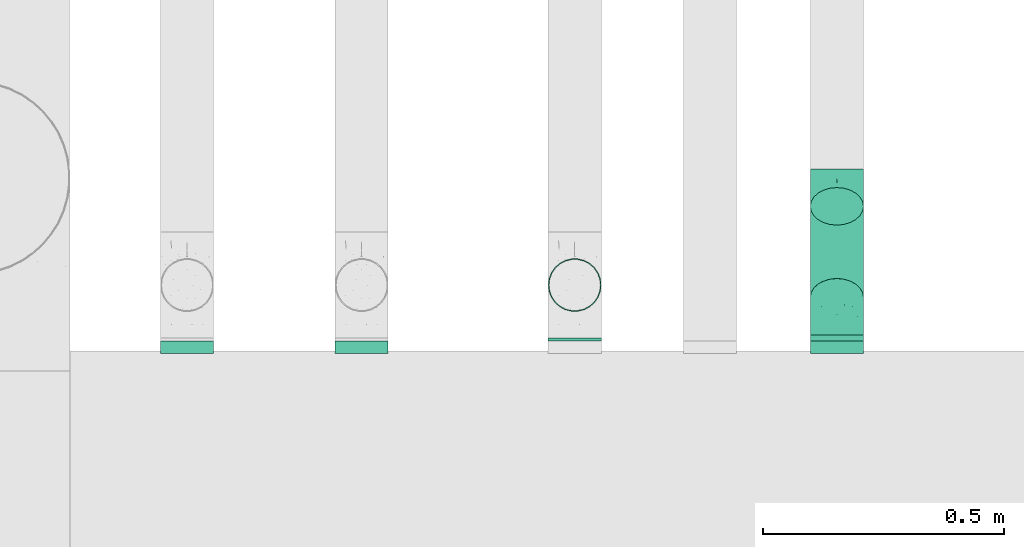
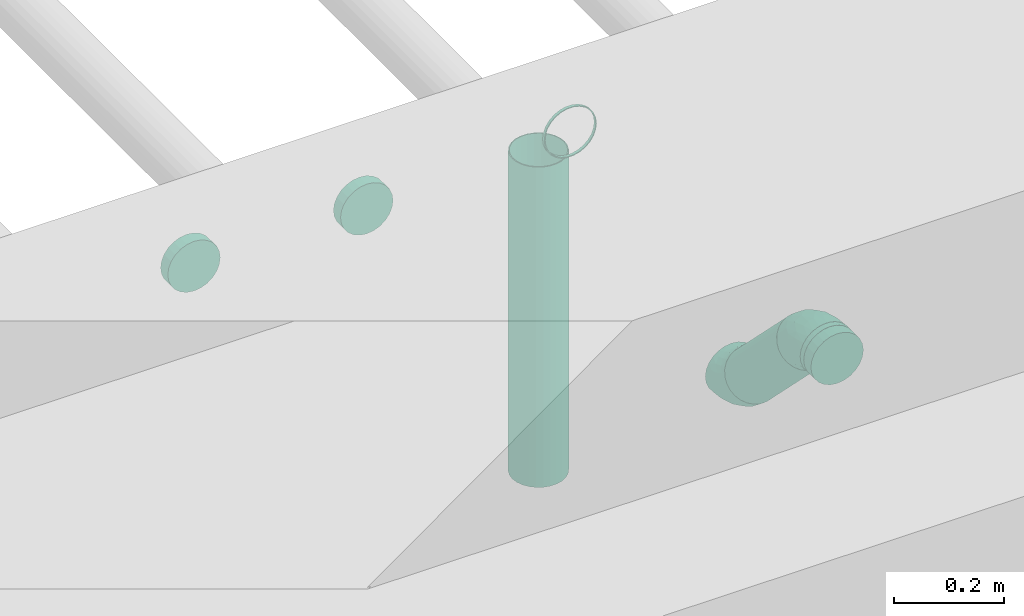
# One storey, part 51 of 91: 5 flow fittings, 4 flow segments.
"""IFC2X3 building model written with IfcOpenShell, lengths in millimetres."""

from ifc_helpers import new_model, entity, si_unit, converted_unit, derived_unit, direction, frame, origin_with_axes, origin_2d_with_axis, place, context, subcontext, project, spatial, hollow_circle, extrude, open_shell, surface_model, source, transform, mapped, material, layer, layer_set, layer_usage, type_object, element, save


model = new_model("IFC2X3")

# Units and contexts
model_context = context("Model", 3, precision=1e-05, world=origin_with_axes(), true_north=direction((0.0, 1.0)))
body_context = subcontext(model_context, "Body", "Model", "MODEL_VIEW")
ifc_project = project(units=[si_unit("AREAUNIT", "SQUARE_METRE"), si_unit("VOLUMEUNIT", "CUBIC_METRE", prefix="DECI"), si_unit("TIMEUNIT", "SECOND"), si_unit("THERMODYNAMICTEMPERATUREUNIT", "DEGREE_CELSIUS"), si_unit("PRESSUREUNIT", "PASCAL"), si_unit("MASSUNIT", "GRAM", prefix="KILO"), si_unit("LENGTHUNIT", "METRE", prefix="MILLI"), si_unit("POWERUNIT", "WATT"), si_unit("ELECTRICCURRENTUNIT", "AMPERE"), si_unit("ELECTRICVOLTAGEUNIT", "VOLT"), derived_unit("VOLUMETRICFLOWRATEUNIT", [(si_unit("VOLUMEUNIT", "CUBIC_METRE", prefix="DECI"), 1), (si_unit("TIMEUNIT", "SECOND"), -1)]), derived_unit("LINEARVELOCITYUNIT", [(si_unit("LENGTHUNIT", "METRE"), 1), (si_unit("TIMEUNIT", "SECOND"), -1)]), derived_unit("MASSDENSITYUNIT", [(si_unit("MASSUNIT", "GRAM", prefix="KILO"), 1), (si_unit("VOLUMEUNIT", "CUBIC_METRE"), -1)]), converted_unit("PLANEANGLEUNIT", "DEGREE", entity("IfcRatioMeasure", 0.01745), si_unit("PLANEANGLEUNIT", "RADIAN"), dimensions=[0, 0, 0, 0, 0, 0, 0])], contexts=[model_context])

# Site, building, storey
site_placement = place(None, origin_with_axes())
site = spatial("IfcSite", under=ifc_project, at=site_placement, CompositionType="ELEMENT")
building_placement = place(site_placement, origin_with_axes())
building = spatial("IfcBuilding", under=site, at=building_placement, Name="mc-building", CompositionType="ELEMENT")
storey_placement = place(building_placement, frame((0.0, 0.0, 8700.0), z_axis=(0.0, 0.0, 1.0), x_axis=(1.0, 0.0, 0.0)))
storey = spatial("IfcBuildingStorey", under=building, at=storey_placement, CompositionType="ELEMENT", Elevation=8700.0)

# Flow segments
ifc_material = material(Name="FZ1")
ifc_layer = layer(ifc_material, 0.0)
ifc_layer_set = layer_set([ifc_layer], Name="FZ1")
ifc_layer_usage = layer_usage(ifc_layer_set, "AXIS1", "POSITIVE", 0.0)
duct_segment_type = type_object("IfcDuctSegmentType", PredefinedType="RIGIDSEGMENT")
shared_shape_1 = source(origin_with_axes(), body_context, "Body", "SweptSolid", [
    extrude(hollow_circle(Radius=55.0, WallThickness=2.0, at=origin_2d_with_axis()), frame((0.0, 0.0, 0.0), z_axis=(1.0, 0.0, 0.0), x_axis=(0.0, 1.0, 0.0)), (0.0, 0.0, 1.0), 709.0),
])
flow_segment_1_placement = place(storey_placement, frame((19046.0369, 8426.54565, 1234.0), z_axis=(0.0, 1.0, 0.0), x_axis=(0.0, 0.0, -1.0)))
element("IfcFlowSegment", 1, at=flow_segment_1_placement, inside=storey, type_object=duct_segment_type, material=ifc_layer_usage, context=body_context, shape_type="MappedRepresentation", body=[
    mapped(shared_shape_1, transform((0.0, 0.0, 0.0), scale=1.0)),
])
shared_shape_2 = source(origin_with_axes(), body_context, "Body", "SweptSolid", [
    extrude(hollow_circle(Radius=55.0, WallThickness=2.0, at=origin_2d_with_axis()), frame((0.0, 0.0, 0.0), z_axis=(1.0, 0.0, 0.0), x_axis=(0.0, 1.0, 0.0)), (0.0, 0.0, 1.0), 266.7),
])
flow_segment_2_placement = place(storey_placement, frame((19589.29598, 8401.1274, 635.78175), z_axis=(0.0, 0.707107, 0.707107), x_axis=(0.0, 0.707107, -0.707107)))
element("IfcFlowSegment", 2, at=flow_segment_2_placement, inside=storey, type_object=duct_segment_type, material=ifc_layer_usage, context=body_context, shape_type="MappedRepresentation", body=[
    mapped(shared_shape_2, transform((0.0, 0.0, 0.0), scale=1.0)),
])

# Flow fittings
duct_fitting_type_1 = type_object("IfcDuctFittingType", Name="BU", PredefinedType="BEND")
shared_shape_3 = source(origin_with_axes(), body_context, "Body", "SurfaceModel", [
    surface_model("IfcShellBasedSurfaceModel", [(-45.56349, 0.0, -55.0), (-45.56349, -14.23505, -53.12592), (-45.56349, 14.23505, -53.12592), (-45.56349, 53.12592, 14.23505), (-45.56349, 27.5, -47.63139), (-45.56349, 38.89087, -38.89087), (-45.56349, 47.63139, -27.5), (-45.56349, -55.0, 0.0), (-45.56349, -53.12592, 14.23505), (-45.56349, -38.89087, -38.89087), (-45.56349, -27.5, -47.63139), (-45.56349, -53.12592, -14.23505), (-45.56349, -47.63139, -27.5), (-45.56349, 53.12592, -14.23505), (-45.56349, 47.63139, 27.5), (-45.56349, 38.89087, 38.89087), (-45.56349, -14.23505, 53.12592), (-45.56349, 27.5, 47.63139), (-45.56349, 14.23505, 53.12592), (-45.56349, -47.63139, 27.5), (-45.56349, -38.89087, 38.89087), (-45.56349, -27.5, 47.63139), (-45.56349, 0.0, 55.0), (-45.56349, 55.0, 0.0), (22.15256, 42.28395, -53.12592), (-6.67262, 71.10913, 0.0), (32.21826, 32.21826, -55.0), (12.77282, 51.66369, -47.63139), (-1.46223, 65.89874, -27.5), (4.71825, 59.71825, -38.89087), (59.71825, 4.71825, -38.89087), (69.78395, -5.34744, 14.23505), (51.66369, 12.77282, -47.63139), (42.28395, 22.15256, -53.12592), (65.89874, -1.46223, -27.5), (69.78395, -5.34744, -14.23505), (71.10913, -6.67262, 0.0), (-5.34744, 69.78395, -14.23505), (-5.34744, 69.78395, 14.23505), (-1.46223, 65.89874, 27.5), (4.71825, 59.71825, 38.89087), (32.21826, 32.21826, 55.0), (12.77282, 51.66369, 47.63139), (22.15256, 42.28395, 53.12592), (59.71825, 4.71825, 38.89087), (65.89874, -1.46223, 27.5), (42.28395, 22.15256, 53.12592), (51.66369, 12.77282, 47.63139), (-20.16649, 48.68621, 33.48188), (-26.97111, 35.77503, 43.63444), (-7.30443, 43.73336, 43.63444), (-17.0934, 3.74816, 55.0), (-18.00408, 15.44793, 53.78143), (-30.11707, 22.39897, 50.81337), (-7.49776, 55.63651, 33.48188), (-15.97018, 58.74288, 21.04759), (-31.18231, 52.58712, 21.04759), (-18.35174, 61.03934, 10.51509), (-28.67677, 56.60048, 10.47121), (-34.03924, 44.64267, 33.48188), (-11.52288, 27.81868, 50.81338), (1.19951, 23.16465, 53.81115), (-33.77926, 57.34403, 0.0), (5.4586, 37.12132, 50.81809), (-24.5159, 59.18663, 0.0), (-16.66281, 64.4339, 0.0), (9.43651, 14.73721, 55.0), (-6.22531, 44.36822, -43.63444), (5.4586, 37.12132, -50.81809), (-34.03924, 44.64267, -33.48188), (9.43651, 14.73721, -55.0), (-17.0934, 3.74816, -55.0), (1.19951, 23.16465, -53.81115), (-11.52288, 27.81868, -50.81338), (-30.11707, 22.39897, -50.81337), (-25.75914, 36.08917, -43.63444), (-30.24487, 52.83011, -21.04759), (-20.16649, 48.68621, -33.48188), (-7.49776, 55.63651, -33.48188), (-18.00408, 15.44793, -53.78143), (-28.68366, 56.62226, -10.35271), (-14.15883, 63.53074, -10.87592), (-15.13548, 59.23394, -21.04759), (3.19797, -7.72059, -52.16847), (3.1272, -18.04126, -47.9241), (13.63233, -32.91136, -32.06475), (45.23618, -22.99734, -20.4997), (16.67434, -40.25541, -15.9539), (-17.3935, -51.68264, -9.80849), (-2.85835, -49.37776, 0.0), (48.84421, -24.24609, -9.80849), (-16.38424, -42.76862, -30.85433), (-6.97383, -29.41689, -42.70541), (41.82739, -18.65658, -30.85433), (-15.72523, -48.24839, -20.4997), (29.28945, -13.63928, -42.80781), (26.81493, -3.56603, -49.15704), (36.93651, -32.89419, 0.0), (-15.72523, -48.24839, 20.4997), (-17.3935, -51.68264, 9.80849), (-16.38424, -42.76862, 30.85433), (16.67434, -40.25541, 15.9539), (3.19797, -7.72059, 52.16847), (10.54583, -14.96836, 47.9241), (13.63233, -32.91136, 32.06475), (45.23618, -22.99734, 20.4997), (41.82739, -18.65658, 30.85433), (-11.06635, -30.3552, 42.80781), (25.73213, -15.86964, 42.70541), (-16.43945, -21.48258, 49.15704), (48.84421, -24.24609, 9.80849)], [open_shell([[[0, 1, 2]], [[2, 3, 4]], [[5, 3, 6]], [[4, 3, 5]], [[2, 7, 8]], [[9, 7, 10]], [[1, 10, 7]], [[11, 7, 12]], [[9, 12, 7]], [[7, 2, 1]], [[13, 6, 3]], [[14, 3, 2]], [[15, 14, 2]], [[16, 17, 2]], [[2, 17, 15]], [[16, 18, 17]], [[19, 20, 2]], [[19, 2, 8]], [[20, 21, 2]], [[2, 21, 16]], [[16, 22, 18]], [[23, 13, 3]], [[24, 25, 26]], [[27, 25, 24]], [[28, 25, 29]], [[29, 25, 27]], [[30, 26, 31]], [[26, 30, 32]], [[32, 33, 26]], [[34, 31, 35]], [[31, 34, 30]], [[35, 31, 36]], [[37, 25, 28]], [[26, 38, 39]], [[26, 39, 40]], [[41, 40, 42]], [[26, 40, 41]], [[42, 43, 41]], [[26, 44, 45]], [[31, 26, 45]], [[46, 47, 26]], [[47, 44, 26]], [[46, 26, 41]], [[26, 25, 38]], [[48, 49, 50]], [[22, 51, 52]], [[17, 49, 15]], [[53, 17, 18]], [[49, 17, 53]], [[54, 50, 40]], [[48, 55, 56]], [[55, 57, 58]], [[59, 14, 15]], [[60, 53, 52]], [[50, 49, 60]], [[58, 3, 56]], [[52, 51, 61]], [[62, 23, 3]], [[63, 50, 60]], [[50, 42, 40]], [[3, 58, 62]], [[43, 61, 41]], [[62, 58, 64]], [[48, 59, 49]], [[14, 56, 3]], [[40, 39, 54]], [[57, 64, 58]], [[39, 38, 55]], [[63, 60, 61]], [[54, 55, 48]], [[65, 57, 38]], [[56, 14, 59]], [[38, 25, 65]], [[60, 52, 61]], [[49, 59, 15]], [[55, 58, 56]], [[56, 59, 48]], [[55, 54, 39]], [[50, 54, 48]], [[18, 22, 52]], [[49, 53, 60]], [[18, 52, 53]], [[61, 51, 66]], [[41, 61, 66]], [[63, 61, 43]], [[43, 42, 63]], [[50, 63, 42]], [[38, 57, 55]], [[64, 57, 65]], [[67, 27, 68]], [[69, 5, 6]], [[70, 71, 72]], [[73, 74, 75]], [[76, 77, 69]], [[29, 78, 28]], [[2, 79, 0]], [[13, 23, 62]], [[2, 74, 79]], [[5, 75, 4]], [[77, 78, 67]], [[13, 62, 80]], [[64, 80, 62]], [[81, 80, 64]], [[67, 73, 75]], [[82, 77, 76]], [[81, 64, 65]], [[76, 69, 6]], [[82, 76, 80]], [[24, 72, 68]], [[74, 2, 4]], [[27, 67, 29]], [[26, 70, 72]], [[69, 75, 5]], [[82, 28, 78]], [[72, 71, 79]], [[6, 13, 76]], [[77, 67, 75]], [[13, 80, 76]], [[82, 37, 28]], [[81, 25, 37]], [[82, 81, 37]], [[75, 69, 77]], [[67, 78, 29]], [[82, 78, 77]], [[75, 74, 4]], [[79, 74, 73]], [[79, 73, 72]], [[79, 71, 0]], [[68, 72, 73]], [[26, 72, 24]], [[67, 68, 73]], [[27, 24, 68]], [[80, 81, 82]], [[25, 81, 65]], [[1, 83, 84]], [[85, 86, 87]], [[0, 71, 1]], [[88, 87, 89]], [[90, 86, 35]], [[91, 92, 85]], [[11, 88, 7]], [[30, 34, 93]], [[11, 12, 94]], [[92, 91, 9]], [[85, 94, 91]], [[94, 85, 87]], [[95, 93, 85]], [[85, 92, 95]], [[83, 71, 70]], [[12, 9, 91]], [[70, 26, 33]], [[96, 84, 83]], [[1, 71, 83]], [[95, 96, 32]], [[95, 30, 93]], [[95, 32, 30]], [[97, 89, 87]], [[34, 86, 93]], [[36, 97, 90]], [[94, 88, 11]], [[34, 35, 86]], [[90, 87, 86]], [[93, 86, 85]], [[32, 96, 33]], [[84, 10, 1]], [[33, 83, 70]], [[94, 12, 91]], [[10, 92, 9]], [[87, 88, 94]], [[7, 88, 89]], [[36, 90, 35]], [[87, 90, 97]], [[84, 95, 92]], [[33, 96, 83]], [[95, 84, 96]], [[10, 84, 92]], [[8, 98, 19]], [[7, 89, 99]], [[19, 98, 100]], [[101, 98, 99]], [[46, 102, 103]], [[104, 105, 106]], [[100, 98, 104]], [[107, 104, 108]], [[16, 51, 22]], [[51, 16, 102]], [[107, 20, 100]], [[107, 109, 21]], [[21, 20, 107]], [[103, 47, 46]], [[101, 89, 97]], [[105, 110, 31]], [[44, 47, 108]], [[105, 104, 101]], [[107, 100, 104]], [[31, 110, 36]], [[109, 16, 21]], [[108, 106, 44]], [[105, 45, 106]], [[41, 66, 46]], [[102, 66, 51]], [[46, 66, 102]], [[104, 98, 101]], [[99, 98, 8]], [[106, 108, 104]], [[110, 101, 97]], [[45, 44, 106]], [[105, 31, 45]], [[20, 19, 100]], [[109, 103, 102]], [[101, 110, 105]], [[36, 110, 97]], [[7, 99, 8]], [[101, 99, 89]], [[103, 107, 108]], [[16, 109, 102]], [[107, 103, 109]], [[47, 103, 108]]])]),
])
for number, where, z_axis, x_axis, name in (
    (3, (19589.29598, 8368.90914, 668.0), (1.0, 0.0, 0.0), (0.0, -0.707107, 0.707107), "BU"),
    (4, (19589.29598, 8621.90914, 415.0), (-1.0, 0.0, 0.0), (0.0, -1.0, 0.0), "BU"),
):
    element("IfcFlowFitting", number, at=place(storey_placement, frame(where, z_axis=z_axis, x_axis=x_axis)), inside=storey, type_object=duct_fitting_type_1, Name=name, context=body_context, shape_type="MappedRepresentation", body=[
        mapped(shared_shape_3, transform((0.0, 0.0, 0.0), scale=1.0)),
    ])
duct_fitting_type_2 = type_object("IfcDuctFittingType", Name="CC", PredefinedType="CONNECTOR")
shared_shape_4 = source(origin_with_axes(), body_context, "Body", "SurfaceModel", [
    surface_model("IfcShellBasedSurfaceModel", [(-6.096, -55.0, 0.0), (-6.096, 0.0, -55.0), (-6.096, -14.23505, -53.12592), (-6.096, -27.5, -47.63139), (-6.096, -38.89087, -38.89087), (-6.096, -47.63139, -27.5), (-6.096, 38.89087, -38.89087), (-6.096, 53.12592, 14.23505), (-6.096, 27.5, -47.63139), (-6.096, 14.23505, -53.12592), (-6.096, 47.63139, -27.5), (-6.096, 53.12592, -14.23505), (-6.096, 55.0, 0.0), (-6.096, -53.12592, -14.23505), (-6.096, -53.12592, 14.23505), (-6.096, -47.63139, 27.5), (-6.096, -38.89087, 38.89087), (-6.096, 0.0, 55.0), (-6.096, -27.5, 47.63139), (-6.096, -14.23505, 53.12592), (-6.096, 38.89087, 38.89087), (-6.096, 47.63139, 27.5), (-6.096, 14.23505, 53.12592), (-6.096, 27.5, 47.63139), (0.0, -14.23505, 53.12592), (0.0, 0.0, 55.0), (0.0, -27.5, 47.63139), (0.0, -38.89087, 38.89087), (0.0, -53.12592, 14.23505), (0.0, -47.63139, 27.5), (0.0, -55.0, 0.0), (0.0, -53.12592, -14.23505), (0.0, -47.63139, -27.5), (0.0, -38.89087, -38.89087), (0.0, -14.23505, -53.12592), (0.0, -27.5, -47.63139), (0.0, 0.0, -55.0), (0.0, 14.23505, -53.12592), (0.0, 27.5, -47.63139), (0.0, 38.89087, -38.89087), (0.0, 53.12592, -14.23505), (0.0, 47.63139, -27.5), (0.0, 55.0, 0.0), (0.0, 53.12592, 14.23505), (0.0, 47.63139, 27.5), (0.0, 38.89087, 38.89087), (0.0, 14.23505, 53.12592), (0.0, 27.5, 47.63139), (20.0, 0.0, -55.0), (20.0, 14.23505, -53.12592), (20.0, -14.23505, -53.12592), (20.0, -53.12592, 14.23505), (20.0, -27.5, -47.63139), (20.0, -47.63139, -27.5), (20.0, -38.89087, -38.89087), (20.0, 55.0, 0.0), (20.0, 53.12592, 14.23505), (20.0, 38.89087, -38.89087), (20.0, 27.5, -47.63139), (20.0, 53.12592, -14.23505), (20.0, 47.63139, -27.5), (20.0, -53.12592, -14.23505), (20.0, -47.63139, 27.5), (20.0, -38.89087, 38.89087), (20.0, 14.23505, 53.12592), (20.0, -27.5, 47.63139), (20.0, -14.23505, 53.12592), (20.0, 47.63139, 27.5), (20.0, 38.89087, 38.89087), (20.0, 27.5, 47.63139), (20.0, 0.0, 55.0), (20.0, -55.0, 0.0)], [open_shell([[[0, 1, 2]], [[3, 0, 2]], [[0, 4, 5]], [[4, 0, 3]], [[6, 1, 7]], [[1, 6, 8]], [[8, 9, 1]], [[6, 7, 10]], [[10, 7, 11]], [[12, 11, 7]], [[13, 0, 5]], [[14, 15, 1]], [[1, 15, 16]], [[17, 16, 18]], [[17, 1, 16]], [[19, 17, 18]], [[20, 21, 1]], [[7, 1, 21]], [[22, 23, 1]], [[23, 20, 1]], [[22, 1, 17]], [[0, 14, 1]], [[24, 25, 17]], [[26, 24, 19]], [[19, 24, 17]], [[16, 27, 18]], [[26, 19, 18]], [[26, 18, 27]], [[28, 29, 15]], [[30, 28, 14]], [[15, 29, 16]], [[28, 15, 14]], [[30, 14, 0]], [[27, 16, 29]], [[31, 30, 0]], [[32, 31, 13]], [[13, 31, 0]], [[4, 33, 5]], [[32, 13, 5]], [[32, 5, 33]], [[34, 35, 3]], [[36, 34, 2]], [[3, 35, 4]], [[34, 3, 2]], [[36, 2, 1]], [[33, 4, 35]], [[37, 36, 1]], [[38, 37, 9]], [[9, 37, 1]], [[6, 39, 8]], [[38, 9, 8]], [[38, 8, 39]], [[40, 41, 10]], [[42, 40, 11]], [[10, 41, 6]], [[40, 10, 11]], [[42, 11, 12]], [[39, 6, 41]], [[43, 42, 12]], [[44, 43, 7]], [[7, 43, 12]], [[20, 45, 21]], [[44, 7, 21]], [[44, 21, 45]], [[46, 47, 23]], [[25, 46, 22]], [[23, 47, 20]], [[46, 23, 22]], [[25, 22, 17]], [[45, 20, 47]], [[48, 49, 50]], [[50, 51, 52]], [[53, 54, 51]], [[52, 51, 54]], [[50, 55, 56]], [[57, 55, 58]], [[49, 58, 55]], [[59, 55, 60]], [[57, 60, 55]], [[55, 50, 49]], [[53, 51, 61]], [[50, 62, 51]], [[63, 62, 50]], [[64, 65, 50]], [[65, 63, 50]], [[64, 66, 65]], [[50, 67, 68]], [[67, 50, 56]], [[68, 69, 50]], [[50, 69, 64]], [[64, 70, 66]], [[71, 61, 51]], [[66, 70, 25]], [[65, 66, 24]], [[24, 66, 25]], [[27, 63, 26]], [[65, 24, 26]], [[65, 26, 63]], [[51, 62, 29]], [[71, 51, 28]], [[29, 62, 27]], [[51, 29, 28]], [[71, 28, 30]], [[63, 27, 62]], [[61, 71, 30]], [[53, 61, 31]], [[31, 61, 30]], [[33, 54, 32]], [[53, 31, 32]], [[53, 32, 54]], [[50, 52, 35]], [[48, 50, 34]], [[35, 52, 33]], [[50, 35, 34]], [[48, 34, 36]], [[54, 33, 52]], [[49, 48, 36]], [[58, 49, 37]], [[37, 49, 36]], [[39, 57, 38]], [[58, 37, 38]], [[58, 38, 57]], [[59, 60, 41]], [[55, 59, 40]], [[41, 60, 39]], [[59, 41, 40]], [[55, 40, 42]], [[57, 39, 60]], [[56, 55, 42]], [[67, 56, 43]], [[43, 56, 42]], [[45, 68, 44]], [[67, 43, 44]], [[67, 44, 68]], [[64, 69, 47]], [[70, 64, 46]], [[47, 69, 45]], [[64, 47, 46]], [[70, 46, 25]], [[68, 45, 69]], [[50, 63, 62]], [[50, 64, 65]], [[50, 56, 67]], [[50, 68, 69]], [[64, 50, 69]]])]),
])
flow_fitting_placement = place(storey_placement, frame((19589.29598, 8290.34565, 668.0), z_axis=(0.0, 0.0, -1.0), x_axis=(0.0, 1.0, 0.0)))
element("IfcFlowFitting", 5, at=flow_fitting_placement, inside=storey, type_object=duct_fitting_type_2, Name="CC", context=body_context, shape_type="MappedRepresentation", body=[
    mapped(shared_shape_4, transform((0.0, 0.0, 0.0), scale=1.0)),
])

# Flow segments
shared_shape_5 = source(origin_with_axes(), body_context, "Body", "SweptSolid", [
    extrude(hollow_circle(Radius=55.0, WallThickness=2.0, at=origin_2d_with_axis()), frame((0.0, 0.0, 0.0), z_axis=(1.0, 0.0, 0.0), x_axis=(0.0, 1.0, 0.0)), (0.0, 0.0, 1.0), 13.0),
])
flow_segment_3_placement = place(storey_placement, frame((19589.29598, 8310.34565, 668.0), z_axis=(0.0, 0.0, 1.0), x_axis=(0.0, 1.0, 0.0)))
element("IfcFlowSegment", 6, at=flow_segment_3_placement, inside=storey, type_object=duct_segment_type, material=ifc_layer_usage, context=body_context, shape_type="MappedRepresentation", body=[
    mapped(shared_shape_5, transform((0.0, 0.0, 0.0), scale=1.0)),
])
shared_shape_6 = source(origin_with_axes(), body_context, "Body", "SweptSolid", [
    extrude(hollow_circle(Radius=55.0, WallThickness=2.0, at=origin_2d_with_axis()), frame((0.0, 0.0, 0.0), z_axis=(1.0, 0.0, 0.0), x_axis=(0.0, 1.0, 0.0)), (0.0, 0.0, 1.0), 6.2),
])
flow_segment_4_placement = place(storey_placement, frame((19046.0369, 8310.34565, 1344.0), z_axis=(0.0, 0.0, 1.0), x_axis=(0.0, 1.0, 0.0)))
element("IfcFlowSegment", 7, at=flow_segment_4_placement, inside=storey, type_object=duct_segment_type, material=ifc_layer_usage, context=body_context, shape_type="MappedRepresentation", body=[
    mapped(shared_shape_6, transform((0.0, 0.0, 0.0), scale=1.0, scale2=1.0, scale3=1.0, uniform=False)),
])

# Flow fittings
shared_shape_7 = source(origin_with_axes(), body_context, "Body", "SurfaceModel", [
    surface_model("IfcShellBasedSurfaceModel", [(-6.096, -55.0, 0.0), (-6.096, 0.0, -55.0), (-6.096, -14.23505, -53.12592), (-6.096, -27.5, -47.63139), (-6.096, -38.89087, -38.89087), (-6.096, -47.63139, -27.5), (-6.096, 38.89087, -38.89087), (-6.096, 53.12592, 14.23505), (-6.096, 27.5, -47.63139), (-6.096, 14.23505, -53.12592), (-6.096, 47.63139, -27.5), (-6.096, 53.12592, -14.23505), (-6.096, 55.0, 0.0), (-6.096, -53.12592, -14.23505), (-6.096, -53.12592, 14.23505), (-6.096, -47.63139, 27.5), (-6.096, -38.89087, 38.89087), (-6.096, 0.0, 55.0), (-6.096, -27.5, 47.63139), (-6.096, -14.23505, 53.12592), (-6.096, 38.89087, 38.89087), (-6.096, 47.63139, 27.5), (-6.096, 14.23505, 53.12592), (-6.096, 27.5, 47.63139), (0.0, -14.23505, 53.12592), (0.0, 0.0, 55.0), (0.0, -27.5, 47.63139), (0.0, -38.89087, 38.89087), (0.0, -53.12592, 14.23505), (0.0, -47.63139, 27.5), (0.0, -55.0, 0.0), (0.0, -53.12592, -14.23505), (0.0, -47.63139, -27.5), (0.0, -38.89087, -38.89087), (0.0, -14.23505, -53.12592), (0.0, -27.5, -47.63139), (0.0, 0.0, -55.0), (0.0, 14.23505, -53.12592), (0.0, 27.5, -47.63139), (0.0, 38.89087, -38.89087), (0.0, 53.12592, -14.23505), (0.0, 47.63139, -27.5), (0.0, 55.0, 0.0), (0.0, 53.12592, 14.23505), (0.0, 47.63139, 27.5), (0.0, 38.89087, 38.89087), (0.0, 14.23505, 53.12592), (0.0, 27.5, 47.63139), (20.0, 0.0, -55.0), (20.0, 14.23505, -53.12592), (20.0, -14.23505, -53.12592), (20.0, -53.12592, 14.23505), (20.0, -27.5, -47.63139), (20.0, -47.63139, -27.5), (20.0, -38.89087, -38.89087), (20.0, 55.0, 0.0), (20.0, 53.12592, 14.23505), (20.0, 38.89087, -38.89087), (20.0, 27.5, -47.63139), (20.0, 53.12592, -14.23505), (20.0, 47.63139, -27.5), (20.0, -53.12592, -14.23505), (20.0, -47.63139, 27.5), (20.0, -38.89087, 38.89087), (20.0, 14.23505, 53.12592), (20.0, -27.5, 47.63139), (20.0, -14.23505, 53.12592), (20.0, 47.63139, 27.5), (20.0, 38.89087, 38.89087), (20.0, 27.5, 47.63139), (20.0, 0.0, 55.0), (20.0, -55.0, 0.0)], [open_shell([[[0, 1, 2]], [[3, 0, 2]], [[0, 4, 5]], [[4, 0, 3]], [[6, 1, 7]], [[1, 6, 8]], [[8, 9, 1]], [[6, 7, 10]], [[10, 7, 11]], [[12, 11, 7]], [[13, 0, 5]], [[14, 15, 1]], [[1, 15, 16]], [[17, 16, 18]], [[17, 1, 16]], [[19, 17, 18]], [[20, 21, 1]], [[7, 1, 21]], [[22, 23, 1]], [[23, 20, 1]], [[22, 1, 17]], [[0, 14, 1]], [[24, 25, 17]], [[26, 24, 19]], [[19, 24, 17]], [[16, 27, 18]], [[26, 19, 18]], [[26, 18, 27]], [[28, 29, 15]], [[30, 28, 14]], [[15, 29, 16]], [[28, 15, 14]], [[30, 14, 0]], [[27, 16, 29]], [[31, 30, 0]], [[32, 31, 13]], [[13, 31, 0]], [[4, 33, 5]], [[32, 13, 5]], [[32, 5, 33]], [[34, 35, 3]], [[36, 34, 2]], [[3, 35, 4]], [[34, 3, 2]], [[36, 2, 1]], [[33, 4, 35]], [[37, 36, 1]], [[38, 37, 9]], [[9, 37, 1]], [[6, 39, 8]], [[38, 9, 8]], [[38, 8, 39]], [[40, 41, 10]], [[42, 40, 11]], [[10, 41, 6]], [[40, 10, 11]], [[42, 11, 12]], [[39, 6, 41]], [[43, 42, 12]], [[44, 43, 7]], [[7, 43, 12]], [[20, 45, 21]], [[44, 7, 21]], [[44, 21, 45]], [[46, 47, 23]], [[25, 46, 22]], [[23, 47, 20]], [[46, 23, 22]], [[25, 22, 17]], [[45, 20, 47]], [[48, 49, 50]], [[50, 51, 52]], [[53, 54, 51]], [[52, 51, 54]], [[50, 55, 56]], [[57, 55, 58]], [[49, 58, 55]], [[59, 55, 60]], [[57, 60, 55]], [[55, 50, 49]], [[53, 51, 61]], [[50, 62, 51]], [[63, 62, 50]], [[64, 65, 50]], [[65, 63, 50]], [[64, 66, 65]], [[50, 67, 68]], [[67, 50, 56]], [[68, 69, 50]], [[50, 69, 64]], [[64, 70, 66]], [[71, 61, 51]], [[66, 70, 25]], [[65, 66, 24]], [[24, 66, 25]], [[27, 63, 26]], [[65, 24, 26]], [[65, 26, 63]], [[51, 62, 29]], [[71, 51, 28]], [[29, 62, 27]], [[51, 29, 28]], [[71, 28, 30]], [[63, 27, 62]], [[61, 71, 30]], [[53, 61, 31]], [[31, 61, 30]], [[33, 54, 32]], [[53, 31, 32]], [[53, 32, 54]], [[50, 52, 35]], [[48, 50, 34]], [[35, 52, 33]], [[50, 35, 34]], [[48, 34, 36]], [[54, 33, 52]], [[49, 48, 36]], [[58, 49, 37]], [[37, 49, 36]], [[39, 57, 38]], [[58, 37, 38]], [[58, 38, 57]], [[59, 60, 41]], [[55, 59, 40]], [[41, 60, 39]], [[59, 41, 40]], [[55, 40, 42]], [[57, 39, 60]], [[56, 55, 42]], [[67, 56, 43]], [[43, 56, 42]], [[45, 68, 44]], [[67, 43, 44]], [[67, 44, 68]], [[64, 69, 47]], [[70, 64, 46]], [[47, 69, 45]], [[64, 47, 46]], [[70, 46, 25]], [[68, 45, 69]], [[50, 63, 62]], [[50, 64, 65]], [[50, 56, 67]], [[50, 68, 69]], [[64, 50, 69]]])]),
])
for number, where, z_axis, x_axis, name in (
    (8, (18242.77608, 8290.34565, 1344.0), (0.0, 0.0, -1.0), (0.0, 1.0, 0.0), "CC"),
    (9, (18604.54349, 8290.34565, 1344.0), (0.0, 0.0, -1.0), (0.0, 1.0, 0.0), "CC"),
):
    element("IfcFlowFitting", number, at=place(storey_placement, frame(where, z_axis=z_axis, x_axis=x_axis)), inside=storey, type_object=duct_fitting_type_2, Name=name, context=body_context, shape_type="MappedRepresentation", body=[
        mapped(shared_shape_7, transform((0.0, 0.0, 0.0), scale=1.0)),
    ])

save(model, "model.ifc")
